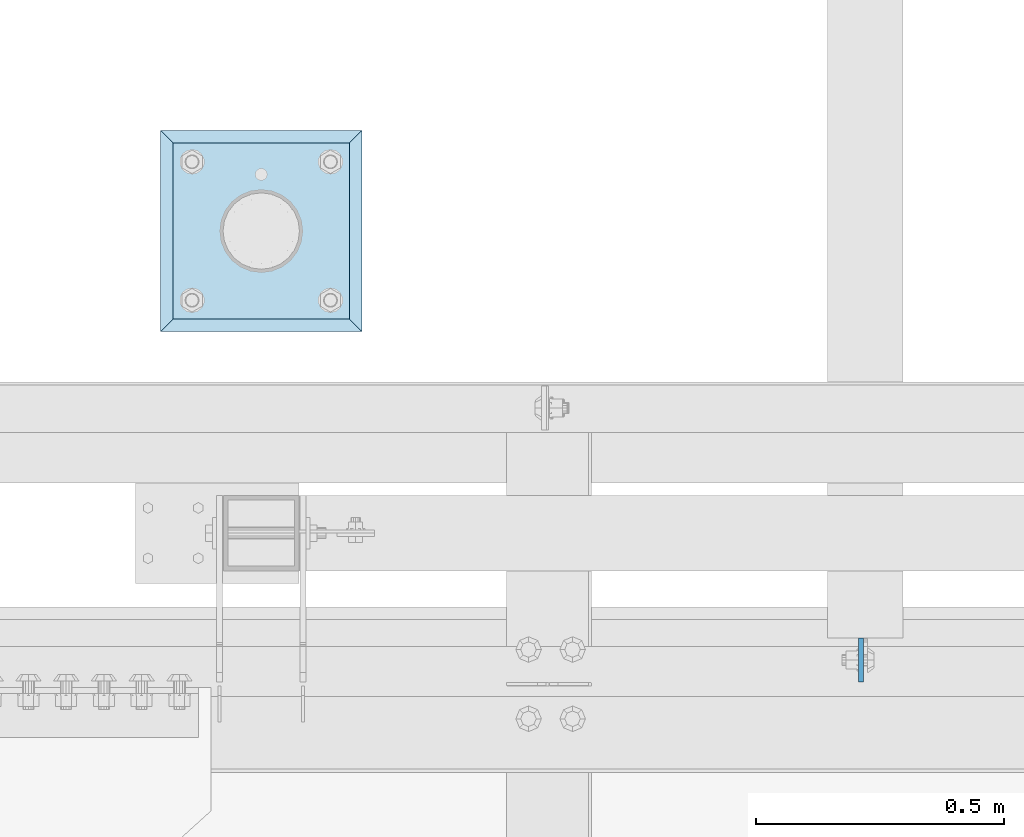
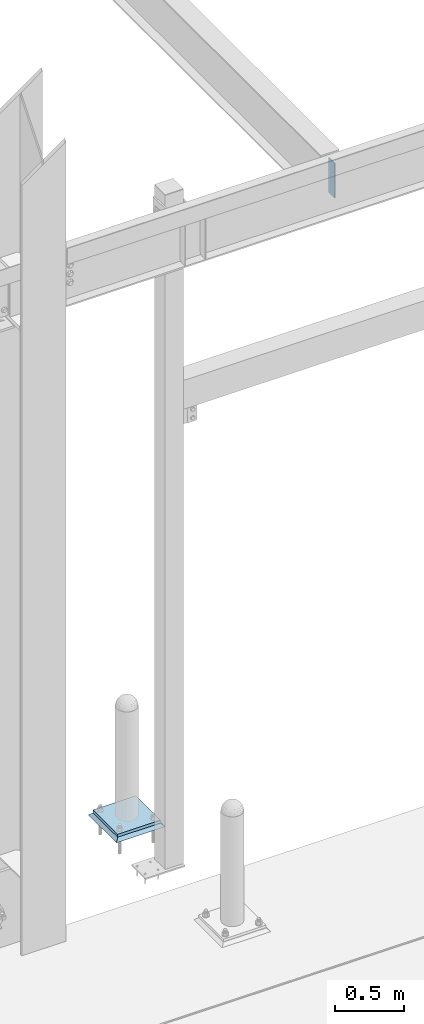
# One storey, part 3499 of 3843: 3 plates, 3 elements without a shape of their own.
"""IFC2X3 building model written with IfcOpenShell, lengths in millimetres."""

import ifcopenshell
import ifcopenshell.guid

model = None  # the IFC model being written
_history = None  # IfcOwnerHistory: only IFC2X3 demands one
_inside = {}  # id of a spatial element -> (the spatial element, [elements in it])
_under = {}  # id of a project, library or spatial element -> (it, [spatial elements below it])
_declared = {}  # id of a project -> (the project, [libraries it declares])
_typed = {}  # id of a type object -> (the type object, [elements of that type])
_made_of = {}  # id of a material, layer set ... -> (it, [elements and type objects made of it])


def new_model(schema):
    """Start an empty IFC model of exactly this schema.

    Asked for "IFC4X3", IfcOpenShell would pick the latest addendum, in which some entities
    have other attributes; the version numbers below select the first issue.
    IFC2X3 requires an IfcOwnerHistory on every rooted entity: one is made here for all.
    """
    global model, _history
    if schema == "IFC4X3":
        model = ifcopenshell.file(schema_version=(4, 3, 0, 0))
    else:
        model = ifcopenshell.file(schema=schema)
    _inside.clear()
    _under.clear()
    _declared.clear()
    _typed.clear()
    _made_of.clear()
    _history = None
    if model.schema == "IFC2X3":
        org = make("IfcOrganization", Name="unknown")
        user = make(
            "IfcPersonAndOrganization",
            ThePerson=make("IfcPerson", FamilyName="unknown"),
            TheOrganization=org,
        )
        app = make(
            "IfcApplication",
            ApplicationDeveloper=org,
            Version="unknown",
            ApplicationFullName="unknown",
            ApplicationIdentifier="unknown",
        )
        _history = make(
            "IfcOwnerHistory",
            OwningUser=user,
            OwningApplication=app,
            ChangeAction="ADDED",
            CreationDate=0,
        )
    return model


def make(cls, **values):
    """One entity of the class cls with the attributes given. An attribute that is None is left unset."""
    return model.create_entity(
        cls, **{name: value for name, value in values.items() if value is not None}
    )


def rooted(cls, **values):
    """An entity with a GlobalId (a new one), such as an element, a storey or a relation."""
    return make(cls, GlobalId=ifcopenshell.guid.new(), OwnerHistory=_history, **values)


def si_unit(unit_type, name, prefix=None):
    """IfcSIUnit, for example si_unit("LENGTHUNIT", "METRE", prefix="MILLI")."""
    return make("IfcSIUnit", UnitType=unit_type, Prefix=prefix, Name=name)


def assignment(units):
    """IfcUnitAssignment: the units of a project."""
    return None if units is None else make("IfcUnitAssignment", Units=units)


def point(xyz):
    """IfcCartesianPoint."""
    return None if xyz is None else make("IfcCartesianPoint", Coordinates=xyz)


def direction(xyz):
    """IfcDirection."""
    return None if xyz is None else make("IfcDirection", DirectionRatios=xyz)


def frame(location, z_axis=None, x_axis=None):
    """IfcAxis2Placement3D, a coordinate frame: its origin and axes. An axis left out is left unset."""
    return make(
        "IfcAxis2Placement3D",
        Location=point(location),
        Axis=direction(z_axis),
        RefDirection=direction(x_axis),
    )


def origin_with_axes():
    """The frame at (0, 0, 0) with the z axis (0, 0, 1) and the x axis (1, 0, 0) written out."""
    return frame((0.0, 0.0, 0.0), z_axis=(0.0, 0.0, 1.0), x_axis=(1.0, 0.0, 0.0))


def place(relative_to, where):
    """IfcLocalPlacement: puts the frame where relative to a parent placement (None: the world)."""
    return make(
        "IfcLocalPlacement", PlacementRelTo=relative_to, RelativePlacement=where
    )


def context(
    kind, dimensions, precision=None, world=None, true_north=None, identifier=None
):
    """IfcGeometricRepresentationContext, for example the 3D "Model" context."""
    return make(
        "IfcGeometricRepresentationContext",
        ContextIdentifier=identifier,
        ContextType=kind,
        CoordinateSpaceDimension=dimensions,
        Precision=precision,
        WorldCoordinateSystem=world,
        TrueNorth=true_north,
    )


def subcontext(parent, identifier, kind, view, scale=None):
    """IfcGeometricRepresentationSubContext, for example "Body" below "Model"."""
    return make(
        "IfcGeometricRepresentationSubContext",
        ContextIdentifier=identifier,
        ContextType=kind,
        ParentContext=parent,
        TargetScale=scale,
        TargetView=view,
    )


def project(units=None, contexts=None):
    """IfcProject with its units and contexts."""
    return rooted(
        "IfcProject",
        Name="project",
        RepresentationContexts=contexts,
        UnitsInContext=assignment(units),
    )


def spatial(cls, under=None, at=None, **own):
    """A site, building, storey or space (cls), placed at a placement, below another one or the project."""
    s = rooted(cls, ObjectPlacement=at, **own)
    if under is not None:
        _under.setdefault(under.id(), (under, []))[1].append(s)
    return s


def faces_of(points, faces, orient=None, outer=None):
    """IfcFace entities. A face is a list of loops; a loop is a list of indices into points, from 0.

    orient and outer hold one flag for each loop. By default every Orientation is true, the
    first loop of a face is its IfcFaceOuterBound and the others are IfcFaceBound.
    """
    made = []
    for i, loops in enumerate(faces):
        bounds = []
        for j, loop in enumerate(loops):
            is_outer = j == 0 if outer is None else outer[i][j]
            bounds.append(
                make(
                    "IfcFaceOuterBound" if is_outer else "IfcFaceBound",
                    Bound=make("IfcPolyLoop", Polygon=[points[k] for k in loop]),
                    Orientation=True if orient is None else orient[i][j],
                )
            )
        made.append(make("IfcFace", Bounds=bounds))
    return made


def faceted_brep(points, faces, orient=None, outer=None, voids=None):
    """IfcFacetedBrep: a solid bounded by flat faces; with voids (closed shells), ...WithVoids."""
    shared = [point(p) for p in points]
    hull = make("IfcClosedShell", CfsFaces=faces_of(shared, faces, orient, outer))
    if voids is None:
        return make("IfcFacetedBrep", Outer=hull)
    return make(
        "IfcFacetedBrepWithVoids",
        Outer=hull,
        Voids=[
            make(cls, CfsFaces=faces_of(shared, fs, o, b)) for cls, fs, o, b in voids
        ],
    )


def shape(context_of_items, identifier, shape_type, items):
    """IfcShapeRepresentation: the items that make up one representation, for example the "Body"."""
    return make(
        "IfcShapeRepresentation",
        ContextOfItems=context_of_items,
        RepresentationIdentifier=identifier,
        RepresentationType=shape_type,
        Items=items,
    )


def material(Name=None, Category=None):
    """IfcMaterial."""
    return make("IfcMaterial", Name=Name, Category=Category)


def made_of(thing, what):
    """Note that an element or type object is made of a material, layer set ...; save() writes the relation."""
    if what is not None:
        _made_of.setdefault(what.id(), (what, []))[1].append(thing)
    return thing


def type_object(cls, material=None, **own):
    """A type object (cls), such as IfcWallType, which elements share."""
    return made_of(rooted(cls, **own), material)


def element(
    cls,
    number,
    at=None,
    inside=None,
    cuts=None,
    type_object=None,
    material=None,
    context=None,
    identifier="Body",
    shape_type=None,
    held_by="IfcProductDefinitionShape",
    body=None,
    shapes=None,
    **own,
):
    """One element of the class cls, such as IfcWall. Its Tag is "e" and its number.

    at: its placement. inside: the storey or other place that contains it. cuts: it is an
    opening in that element (IfcRelVoidsElement). A single representation is given by context,
    identifier, shape_type and body (its items); several are given by shapes. held_by: the class
    of the entity that holds the representations. save() writes the other relations.
    """
    e = rooted(cls, Tag="e%d" % number, ObjectPlacement=at, **own)
    if body is not None:
        shapes = [shape(context, identifier, shape_type, body)]
    if shapes is not None:
        e.Representation = make(held_by, Representations=shapes)
    if inside is not None:
        _inside.setdefault(inside.id(), (inside, []))[1].append(e)
    if cuts is not None:
        rooted(
            "IfcRelVoidsElement", RelatingBuildingElement=cuts, RelatedOpeningElement=e
        )
    if type_object is not None:
        _typed.setdefault(type_object.id(), (type_object, []))[1].append(e)
    return made_of(e, material)


def aggregate(whole, parts):
    """IfcRelAggregates: a whole, such as a stair, and the parts it consists of."""
    return rooted("IfcRelAggregates", RelatingObject=whole, RelatedObjects=parts)


def save(model, path):
    """Write the relations noted so far, then the file.

    IfcRelAggregates (storeys below a building ...), IfcRelContainedInSpatialStructure (elements
    in a storey), IfcRelDefinesByType, IfcRelAssociatesMaterial and IfcRelDeclares: one each for
    every whole, place, type object, material and project.
    """
    for whole, parts in _under.values():
        aggregate(whole, parts)
    for where, things in _inside.values():
        rooted(
            "IfcRelContainedInSpatialStructure",
            RelatedElements=things,
            RelatingStructure=where,
        )
    for kind, things in _typed.values():
        rooted("IfcRelDefinesByType", RelatedObjects=things, RelatingType=kind)
    for what, things in _made_of.values():
        rooted("IfcRelAssociatesMaterial", RelatedObjects=things, RelatingMaterial=what)
    for by, libraries in _declared.values():
        rooted("IfcRelDeclares", RelatingContext=by, RelatedDefinitions=libraries)
    model.write(path)


model = new_model("IFC2X3")

# Units and contexts
model_context = context("Model", 3, precision=1e-05, world=origin_with_axes())
body_context = subcontext(model_context, "Body", "Model", "MODEL_VIEW")
ifc_project = project(units=[si_unit("LENGTHUNIT", "METRE", prefix="MILLI"), si_unit("AREAUNIT", "SQUARE_METRE"), si_unit("VOLUMEUNIT", "CUBIC_METRE"), si_unit("MASSUNIT", "GRAM", prefix="KILO"), si_unit("TIMEUNIT", "SECOND"), si_unit("PLANEANGLEUNIT", "RADIAN"), si_unit("SOLIDANGLEUNIT", "STERADIAN"), si_unit("THERMODYNAMICTEMPERATUREUNIT", "DEGREE_CELSIUS"), si_unit("LUMINOUSINTENSITYUNIT", "LUMEN")], contexts=[model_context])

# Site, building, storey
site_placement = place(None, origin_with_axes())
site = spatial("IfcSite", under=ifc_project, at=site_placement, CompositionType="ELEMENT")
building_placement = place(site_placement, origin_with_axes())
building = spatial("IfcBuilding", under=site, at=building_placement, Name="Undefined", CompositionType="ELEMENT")
storey_placement = place(building_placement, origin_with_axes())
storey = spatial("IfcBuildingStorey", under=building, at=storey_placement, Name="Undefined", CompositionType="ELEMENT", Elevation=0.0)

# Assembly, plate
assembly_1_placement = place(storey_placement, origin_with_axes())
assembly_1 = element("IfcElementAssembly", 1, at=assembly_1_placement, inside=storey, Name="PIPE_BOLLARD", AssemblyPlace="NOTDEFINED", PredefinedType="RIGID_FRAME")
ifc_material_1 = material(Name="STEEL/A572-50")
plate_type_1 = type_object("IfcPlateType", PredefinedType="NOTDEFINED")
plate_1_placement = place(assembly_1_placement, frame((63779.4, 92951.3, 30518.1), z_axis=(0.0, 1.0, 0.0), x_axis=(1.0, 0.0, 0.0)))
plate_1 = element("IfcPlate", 2, at=plate_1_placement, type_object=plate_type_1, material=ifc_material_1, Name="PLATE", context=body_context, shape_type="Brep", body=[
    faceted_brep([(0.0, -12.6999999999971, 0.0), (0.0, -12.7000000000007, 355.600000000006), (0.0, 12.7000000000007, 355.600000000006), (0.0, 12.6999999999971, 0.0), (355.599999999999, -12.7000000000007, 355.600000000006), (355.599999999999, 12.7000000000007, 355.600000000006), (355.599999999999, -12.7000000000007, 0.0), (355.599999999999, 12.7000000000007, 0.0)], [[[0, 1, 2, 3]], [[1, 4, 5, 2]], [[4, 6, 7, 5]], [[6, 0, 3, 7]], [[5, 7, 3, 2]], [[6, 4, 1, 0]]]),
])
aggregate(assembly_1, [plate_1])

assembly_2_placement = place(storey_placement, origin_with_axes())
assembly_2 = element("IfcElementAssembly", 3, at=assembly_2_placement, inside=storey, Name="GROUT", AssemblyPlace="NOTDEFINED", PredefinedType="REINFORCEMENT_UNIT")
ifc_material_2 = material(Name="CONCRETE/Concrete_Undefined")
plate_type_2 = type_object("IfcPlateType", PredefinedType="NOTDEFINED")
plate_2_placement = place(assembly_2_placement, frame((63754.0, 92925.9, 30492.7), z_axis=(0.0, 1.0, 0.0), x_axis=(1.0, 0.0, 0.0)))
plate_2 = element("IfcPlate", 4, at=plate_2_placement, type_object=plate_type_2, material=ifc_material_2, Name="GROUT", context=body_context, shape_type="Brep", body=[
    faceted_brep([(25.4000000001906, -12.6999999998552, 380.999999999505), (0.0, 12.7000000000007, 406.399999999994), (0.0, 12.6999999999971, 0.0), (25.4000000001906, -12.6999999999898, 25.4000000004453), (380.999999999833, -12.6999999998588, 25.4000000004453), (406.400000000001, 12.7000000000007, 0.0), (406.400000000001, 12.7000000000007, 406.399999999994), (380.999999999833, -12.6999999999898, 380.999999999505)], [[[0, 1, 2, 3]], [[4, 5, 6, 7]], [[4, 7, 0, 3]], [[5, 4, 3, 2]], [[6, 5, 2, 1]], [[7, 6, 1, 0]]]),
])
aggregate(assembly_2, [plate_2])

assembly_3_placement = place(storey_placement, origin_with_axes())
assembly_3 = element("IfcElementAssembly", 5, at=assembly_3_placement, inside=storey, Name="BEAM", AssemblyPlace="NOTDEFINED", PredefinedType="RIGID_FRAME")
plate_type_3 = type_object("IfcPlateType", PredefinedType="NOTDEFINED")
plate_3_placement = place(assembly_3_placement, frame((65167.66875, 92218.66875, 36398.2), z_axis=(0.0, 1.0, 0.0), x_axis=(0.0, 0.0, -1.0)))
plate_3 = element("IfcPlate", 6, at=plate_3_placement, type_object=plate_type_3, material=ifc_material_1, Name="PLATE", context=body_context, shape_type="Brep", body=[
    faceted_brep([(0.0, -4.76249999999709, 0.0), (0.0, -4.76249999999709, 88.9000015258789), (0.0, 4.76249999999709, 88.9000015258789), (0.0, 4.76249999999709, 0.0), (304.800000000003, -4.76249999999709, 88.8999999999942), (304.800000000003, 4.76249999999709, 88.8999999999942), (304.800000000003, -4.76249999999709, 0.0), (304.800000000003, 4.76249999999709, 0.0)], [[[0, 1, 2, 3]], [[1, 4, 5, 2]], [[4, 6, 7, 5]], [[6, 0, 3, 7]], [[5, 7, 3, 2]], [[6, 4, 1, 0]]]),
])
aggregate(assembly_3, [plate_3])

save(model, "model.ifc")
